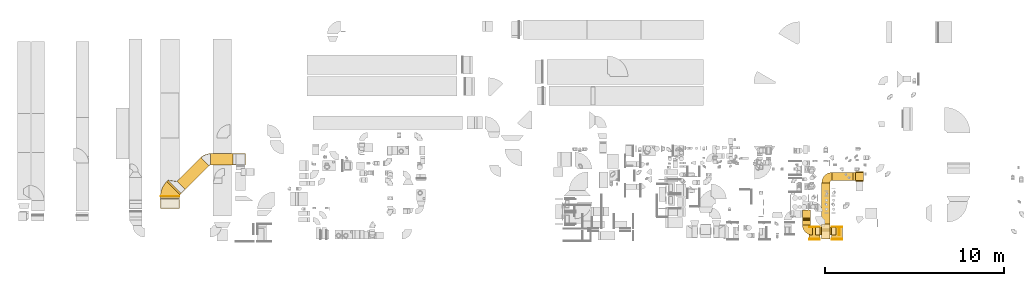
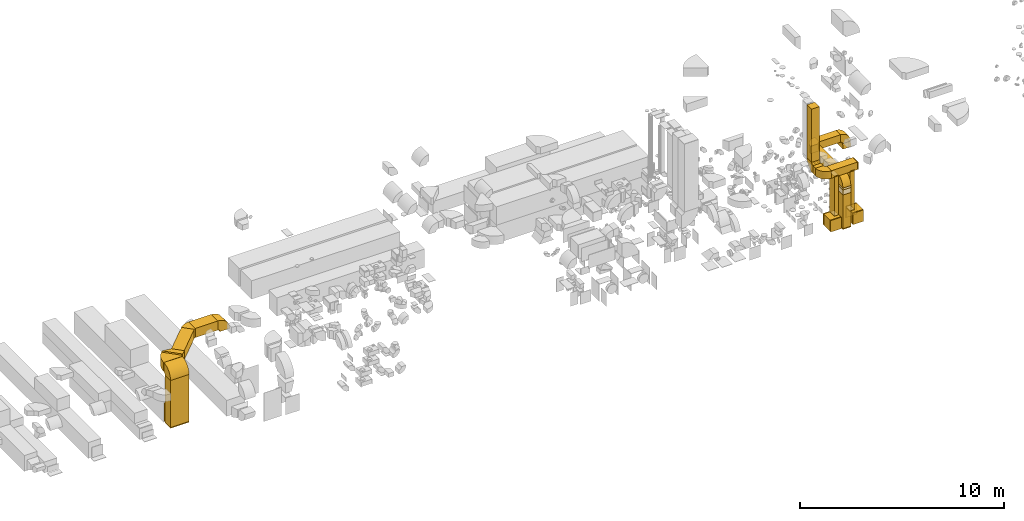
# One storey, part 1 of 59: 40 coverings.
"""IFC2X3 building model written with IfcOpenShell, lengths in millimetres."""

from ifc_helpers import new_model, entity, si_unit, converted_unit, derived_unit, direction, frame, frame_2d, origin, origin_2d_with_axis, place, context, subcontext, project, spatial, polyline, circle_curve, parameter, trimmed, segment, composite_curve, rectangle, outline, extrude, element, save


model = new_model("IFC2X3")

# Units and contexts
model_context = context("Model", 3, precision=0.01, world=origin(), true_north=direction((6.12303176911189e-17, 1.0)))
body_context = subcontext(model_context, "Body", "Model", "MODEL_VIEW")
ifc_project = project(units=[si_unit("LENGTHUNIT", "METRE", prefix="MILLI"), si_unit("AREAUNIT", "SQUARE_METRE"), si_unit("VOLUMEUNIT", "CUBIC_METRE"), converted_unit("PLANEANGLEUNIT", "DEGREE", entity("IfcRatioMeasure", 0.0174532925199433), si_unit("PLANEANGLEUNIT", "RADIAN"), dimensions=[0, 0, 0, 0, 0, 0, 0]), si_unit("MASSUNIT", "GRAM", prefix="KILO"), derived_unit("MASSDENSITYUNIT", [(si_unit("MASSUNIT", "GRAM", prefix="KILO"), 1), (si_unit("LENGTHUNIT", "METRE"), -3)]), derived_unit("MOMENTOFINERTIAUNIT", [(si_unit("LENGTHUNIT", "METRE"), 4)]), si_unit("TIMEUNIT", "SECOND"), si_unit("FREQUENCYUNIT", "HERTZ"), si_unit("THERMODYNAMICTEMPERATUREUNIT", "DEGREE_CELSIUS"), derived_unit("THERMALTRANSMITTANCEUNIT", [(si_unit("MASSUNIT", "GRAM", prefix="KILO"), 1), (si_unit("THERMODYNAMICTEMPERATUREUNIT", "KELVIN"), -1), (si_unit("TIMEUNIT", "SECOND"), -3)]), derived_unit("VOLUMETRICFLOWRATEUNIT", [(si_unit("LENGTHUNIT", "METRE"), 3), (si_unit("TIMEUNIT", "SECOND"), -1)]), derived_unit("MASSFLOWRATEUNIT", [(si_unit("MASSUNIT", "GRAM", prefix="KILO"), 1), (si_unit("TIMEUNIT", "SECOND"), -1)]), derived_unit("ROTATIONALFREQUENCYUNIT", [(si_unit("TIMEUNIT", "SECOND"), -1)]), si_unit("ELECTRICCURRENTUNIT", "AMPERE"), si_unit("ELECTRICVOLTAGEUNIT", "VOLT"), si_unit("POWERUNIT", "WATT"), si_unit("FORCEUNIT", "NEWTON", prefix="KILO"), si_unit("ILLUMINANCEUNIT", "LUX"), si_unit("LUMINOUSFLUXUNIT", "LUMEN"), si_unit("LUMINOUSINTENSITYUNIT", "CANDELA"), derived_unit("USERDEFINED", [(si_unit("MASSUNIT", "GRAM", prefix="KILO"), -1), (si_unit("LENGTHUNIT", "METRE"), -2), (si_unit("TIMEUNIT", "SECOND"), 3), (si_unit("LUMINOUSFLUXUNIT", "LUMEN"), 1)]), derived_unit("LINEARVELOCITYUNIT", [(si_unit("LENGTHUNIT", "METRE"), 1), (si_unit("TIMEUNIT", "SECOND"), -1)]), si_unit("PRESSUREUNIT", "PASCAL"), derived_unit("USERDEFINED", [(si_unit("LENGTHUNIT", "METRE"), -2), (si_unit("MASSUNIT", "GRAM", prefix="KILO"), 1), (si_unit("TIMEUNIT", "SECOND"), -2)]), derived_unit("LINEARFORCEUNIT", [(si_unit("MASSUNIT", "GRAM", prefix="KILO"), 1), (si_unit("LENGTHUNIT", "METRE"), 1), (si_unit("TIMEUNIT", "SECOND"), -2), (si_unit("LENGTHUNIT", "METRE"), -1)]), derived_unit("PLANARFORCEUNIT", [(si_unit("MASSUNIT", "GRAM", prefix="KILO"), 1), (si_unit("LENGTHUNIT", "METRE"), 1), (si_unit("TIMEUNIT", "SECOND"), -2), (si_unit("LENGTHUNIT", "METRE"), -2)])], contexts=[model_context])

# Site, building, storey
site_placement = place(None, origin())
site = spatial("IfcSite", under=ifc_project, at=site_placement, CompositionType="ELEMENT")
building_placement = place(site_placement, origin())
building = spatial("IfcBuilding", under=site, at=building_placement, CompositionType="ELEMENT")
storey_placement = place(building_placement, frame((0.0, 0.0, 28200.0)))
storey = spatial("IfcBuildingStorey", under=building, at=storey_placement, CompositionType="ELEMENT", Elevation=28200.0)

# Coverings
for number, where in (
    (1, (56172.0, 7958.29, 277.0)),
    (2, (57422.0, 7958.29, 277.0)),
):
    element("IfcCovering", number, at=place(storey_placement, frame(where)), inside=storey, PredefinedType="INSULATION", context=body_context, shape_type="SweptSolid", body=[
        extrude(rectangle(XDim=630.0, YDim=600.000000000002, at=origin_2d_with_axis()), frame((300.0, 315.0, 0.0), z_axis=(0.0, 0.0, 1.0), x_axis=(0.0, 1.0, 0.0)), (0.0, 0.0, 1.0), 680.000000000001),
    ])
for number, where in (
    (3, (56522.0, 8163.29, 952.0)),
    (4, (57422.0, 8163.29, 952.0)),
):
    element("IfcCovering", number, at=place(storey_placement, frame(where)), inside=storey, PredefinedType="INSULATION", context=body_context, shape_type="SweptSolid", body=[
        extrude(rectangle(XDim=449.999999999999, YDim=249.999999999995, at=origin_2d_with_axis()), frame((125.0, 225.0, 0.0), z_axis=(0.0, 0.0, 1.0), x_axis=(0.0, -1.0, 0.0)), (0.0, 0.0, 1.0), 2328.0),
    ])
covering_1_placement = place(storey_placement, frame((56172.0, 8588.29, 277.0)))
element("IfcCovering", 5, at=covering_1_placement, inside=storey, PredefinedType="INSULATION", context=body_context, shape_type="SweptSolid", body=[
    extrude(rectangle(XDim=50.0000000000016, YDim=600.000000000002, at=origin_2d_with_axis()), frame((300.0, 25.0, 0.0), z_axis=(0.0, 0.0, 1.0), x_axis=(0.0, -1.0, 0.0)), (0.0, 0.0, 1.0), 680.000000000001),
])
covering_2_placement = place(storey_placement, frame((57422.0, 7908.29, 277.0)))
element("IfcCovering", 6, at=covering_2_placement, inside=storey, PredefinedType="INSULATION", context=body_context, shape_type="SweptSolid", body=[
    extrude(rectangle(XDim=50.0000000000016, YDim=600.000000000002, at=origin_2d_with_axis()), frame((300.0, 25.0, 0.0), z_axis=(0.0, 0.0, 1.0), x_axis=(0.0, 1.0, 0.0)), (0.0, 0.0, 1.0), 680.000000000001),
])
covering_3_placement = place(storey_placement, frame((57422.0, 8588.29, 277.0)))
element("IfcCovering", 7, at=covering_3_placement, inside=storey, PredefinedType="INSULATION", context=body_context, shape_type="SweptSolid", body=[
    extrude(rectangle(XDim=50.0000000000016, YDim=600.000000000002, at=origin_2d_with_axis()), frame((300.0, 25.0, 0.0), z_axis=(0.0, 0.0, 1.0), x_axis=(0.0, -1.0, 0.0)), (0.0, 0.0, 1.0), 680.000000000001),
])
covering_4_placement = place(storey_placement, frame((56361.0, 8163.29, 3275.0)))
element("IfcCovering", 8, at=covering_4_placement, inside=storey, PredefinedType="INSULATION", context=body_context, shape_type="SweptSolid", body=[
    extrude(rectangle(XDim=1467.5, YDim=449.999999999999, at=origin_2d_with_axis()), frame((733.75, 225.0, 0.0), z_axis=(0.0, 0.0, 1.0), x_axis=(-1.0, 0.0, 0.0)), (0.0, 0.0, 1.0), 450.000000000002),
])
covering_5_placement = place(storey_placement, frame((55786.0, 8738.29, 3275.0)))
element("IfcCovering", 9, at=covering_5_placement, inside=storey, PredefinedType="INSULATION", context=body_context, shape_type="SweptSolid", body=[
    extrude(rectangle(XDim=244.711194999999, YDim=450.000000000002, at=origin_2d_with_axis()), frame((225.0, 122.36, 0.0), z_axis=(0.0, 0.0, 1.0), x_axis=(0.0, 1.0, 0.0)), (0.0, 0.0, 1.0), 450.000000000002),
])
covering_6_placement = place(storey_placement, frame((55786.0, 9108.0, 3850.0)))
element("IfcCovering", 10, at=covering_6_placement, inside=storey, PredefinedType="INSULATION", context=body_context, shape_type="SweptSolid", body=[
    extrude(rectangle(XDim=449.999999999999, YDim=450.000000000002, at=origin_2d_with_axis()), frame((225.0, 225.0, 0.0), z_axis=(0.0, 0.0, 1.0), x_axis=(0.0, 1.0, 0.0)), (0.0, 0.0, 1.0), 3175.169278549),
])
for number, where in (
    (11, (56522.0, 8163.29, 900.9)),
    (12, (56522.0, 8163.29, 3280.0)),
    (13, (57422.0, 8163.29, 900.9)),
    (14, (57422.0, 8163.29, 3280.0)),
):
    element("IfcCovering", number, at=place(storey_placement, frame(where)), inside=storey, PredefinedType="INSULATION", context=body_context, shape_type="SweptSolid", body=[
        extrude(rectangle(XDim=449.999999999999, YDim=250.000000000004, at=origin_2d_with_axis()), frame((125.0, 225.0, 0.0), z_axis=(0.0, 0.0, 1.0), x_axis=(0.0, -1.0, 0.0)), (0.0, 0.0, 1.0), 51.0960000000016),
    ])
covering_7_placement = place(storey_placement, frame((57828.5, 8163.29, 3275.0)))
element("IfcCovering", 15, at=covering_7_placement, inside=storey, PredefinedType="INSULATION", context=body_context, shape_type="SweptSolid", body=[
    extrude(rectangle(XDim=49.9999999999973, YDim=450.000000000001, at=origin_2d_with_axis()), frame((25.0, 225.0, 0.0), z_axis=(0.0, 0.0, 1.0), x_axis=(-1.0, 0.0, 0.0)), (0.0, 0.0, 1.0), 450.000000000002),
])
covering_8_placement = place(storey_placement, frame((56172.0, 7908.29, 277.0)))
element("IfcCovering", 16, at=covering_8_placement, inside=storey, PredefinedType="INSULATION", context=body_context, shape_type="SweptSolid", body=[
    extrude(rectangle(XDim=50.0000000000016, YDim=600.000000000002, at=origin_2d_with_axis()), frame((300.0, 25.0, 0.0), z_axis=(0.0, 0.0, 1.0), x_axis=(0.0, 1.0, 0.0)), (0.0, 0.0, 1.0), 680.000000000001),
])
covering_9_placement = place(storey_placement, frame((22661.4, 12073.31, 3175.0)))
element("IfcCovering", 17, at=covering_9_placement, inside=storey, PredefinedType="INSULATION", context=body_context, shape_type="SweptSolid", body=[
    extrude(rectangle(XDim=1267.90195093996, YDim=650.0, at=origin_2d_with_axis()), frame((633.95, 325.0, 0.0), z_axis=(0.0, 0.0, 1.0), x_axis=(-1.0, 0.0, 0.0)), (0.0, 0.0, 1.0), 549.999999999996),
])
covering_10_placement = place(storey_placement, frame((19864.38, 9661.65, 242.0)))
element("IfcCovering", 18, at=covering_10_placement, inside=storey, PredefinedType="INSULATION", context=body_context, shape_type="SweptSolid", body=[
    extrude(rectangle(XDim=550.000000000001, YDim=1050.0, at=origin_2d_with_axis()), frame((525.0, 275.0, 0.0), z_axis=(0.0, 0.0, 1.0), x_axis=(0.0, -1.0, 0.0)), (0.0, 0.0, 1.0), 2808.00000000001),
])
covering_11_placement = place(storey_placement, frame((19864.38, 10326.3, 3175.0)))
element("IfcCovering", 19, at=covering_11_placement, inside=storey, PredefinedType="INSULATION", context=body_context, shape_type="SweptSolid", body=[
    extrude(rectangle(XDim=10.3524324444996, YDim=1050.0, at=origin_2d_with_axis()), frame((525.0, 5.18, 0.0), z_axis=(0.0, -1.35659843300878e-07, 1.0), x_axis=(0.0, -1.0, -1.35659843300878e-07)), (0.0, 0.0, 1.0), 550.000000000001),
])
covering_12_placement = place(storey_placement, frame((20208.53, 10414.68, 3175.0)))
element("IfcCovering", 20, at=covering_12_placement, inside=storey, PredefinedType="INSULATION", context=body_context, shape_type="SweptSolid", body=[
    extrude(rectangle(XDim=110.761184457499, YDim=1050.0, at=origin_2d_with_axis()), frame((410.39, 410.39, 0.0), z_axis=(-7.55457589572577e-09, -7.55457589572588e-09, 1.0), x_axis=(0.707106781186538, 0.707106781186557, 1.06837836897123e-08)), (0.0, 0.0, 1.0), 549.999999999996),
])
covering_13_placement = place(storey_placement, frame((20781.82, 10705.14, 3175.0)))
element("IfcCovering", 21, at=covering_13_placement, inside=storey, PredefinedType="INSULATION", context=body_context, shape_type="SweptSolid", body=[
    extrude(rectangle(XDim=1883.11718226002, YDim=649.999999999997, at=origin_2d_with_axis()), frame((895.59, 895.59, 0.0), z_axis=(-1.10951751218412e-09, -1.10951751218413e-09, 1.0), x_axis=(0.707106781186549, 0.707106781186546, 1.56909471342124e-09)), (0.0, 0.0, 1.0), 549.999999999996),
])
covering_14_placement = place(storey_placement, frame((20286.85, 10493.0, 3175.0)))
element("IfcCovering", 22, at=covering_14_placement, inside=storey, PredefinedType="INSULATION", context=body_context, shape_type="SweptSolid", body=[
    extrude(outline(polyline([(-150.0, -425.0), (150.0, -425.0), (150.0, 225.0), (-150.0, 625.0), (-150.0, -425.0)])), frame((548.01, 406.59, 0.0), z_axis=(-4.57021901919309e-08, -4.57021901919276e-08, 1.0), x_axis=(0.707106781186727, 0.707106781186366, 6.4632657199581e-08)), (0.0, 0.0, 1.0), 549.999999999997),
])
covering_15_placement = place(storey_placement, frame((19864.38, 9661.65, 192.0)))
element("IfcCovering", 23, at=covering_15_placement, inside=storey, PredefinedType="INSULATION", context=body_context, shape_type="SweptSolid", body=[
    extrude(rectangle(XDim=550.0, YDim=1050.0, at=origin_2d_with_axis()), frame((525.0, 275.0, 0.0), z_axis=(0.0, 0.0, 1.0), x_axis=(0.0, 1.0, 0.0)), (0.0, 0.0, 1.0), 50.0000000000016),
])
covering_16_placement = place(storey_placement, frame((19864.38, 10206.65, 257.0)))
element("IfcCovering", 24, at=covering_16_placement, inside=storey, PredefinedType="INSULATION", context=body_context, shape_type="SweptSolid", body=[
    extrude(rectangle(XDim=119.999999999994, YDim=1050.0, at=origin_2d_with_axis()), frame((525.0, 60.0, 0.0), z_axis=(0.0, 0.0, 1.0), x_axis=(0.0, -1.0, 0.0)), (0.0, 0.0, 1.0), 1050.0),
])
covering_17_placement = place(storey_placement, frame((57447.0, 11214.32, 2775.0)))
element("IfcCovering", 25, at=covering_17_placement, inside=storey, PredefinedType="INSULATION", context=body_context, shape_type="SweptSolid", body=[
    extrude(rectangle(XDim=1182.90417000001, YDim=450.000000000002, at=origin_2d_with_axis()), frame((591.45, 225.0, 0.0), z_axis=(0.0, 0.0, 1.0), x_axis=(-1.0, 0.0, 0.0)), (0.0, 0.0, 1.0), 450.000000000002),
])
covering_18_placement = place(storey_placement, frame((56872.0, 8504.29, 2775.0)))
element("IfcCovering", 26, at=covering_18_placement, inside=storey, PredefinedType="INSULATION", context=body_context, shape_type="SweptSolid", body=[
    extrude(rectangle(XDim=2585.02945260871, YDim=450.000000000002, at=origin_2d_with_axis()), frame((225.0, 1292.51, 0.0), z_axis=(0.0, -1.90059958557437e-08, 1.0), x_axis=(0.0, -1.0, -1.90059958557437e-08)), (0.0, 0.0, 1.0), 450.000000000002),
])
covering_19_placement = place(storey_placement, frame((56872.0, 7929.29, 2532.17)))
element("IfcCovering", 27, at=covering_19_placement, inside=storey, PredefinedType="INSULATION", context=body_context, shape_type="SweptSolid", body=[
    extrude(rectangle(XDim=450.000000000002, YDim=449.999999999999, at=origin_2d_with_axis()), frame((225.0, 225.0, 0.0), z_axis=(0.0, 0.0, 1.0), x_axis=(-1.0, 0.0, 0.0)), (0.0, 0.0, 1.0), 117.830633338828),
])
covering_20_placement = place(storey_placement, frame((56872.0, 7929.21, 217.57)))
element("IfcCovering", 28, at=covering_20_placement, inside=storey, PredefinedType="INSULATION", context=body_context, shape_type="SweptSolid", body=[
    extrude(rectangle(XDim=850.0, YDim=450.000000000002, at=origin_2d_with_axis()), frame((225.0, 425.0, 0.0), z_axis=(0.0, 0.0, 1.0), x_axis=(0.0, 1.0, 0.0)), (0.0, 0.0, 1.0), 2014.6001016),
])
covering_21_placement = place(storey_placement, frame((56872.0, 7929.21, 2232.17)))
element("IfcCovering", 29, at=covering_21_placement, inside=storey, PredefinedType="INSULATION", context=body_context, shape_type="SweptSolid", body=[
    extrude(outline(polyline([(-149.91, -325.0), (150.09, -325.0), (149.86, 525.0), (-150.03, 125.0), (-149.91, -325.0)])), frame((0.0, 325.04, 150.0), z_axis=(1.0, 0.0, 0.0), x_axis=(0.0, -0.000269427198978266, -0.999999963704492)), (0.0, 0.0, 1.0), 449.999999999993),
])
covering_22_placement = place(storey_placement, frame((56872.0, 7929.21, 167.57)))
element("IfcCovering", 30, at=covering_22_placement, inside=storey, PredefinedType="INSULATION", context=body_context, shape_type="SweptSolid", body=[
    extrude(rectangle(XDim=450.000000000002, YDim=850.000000000001, at=origin_2d_with_axis()), frame((225.0, 425.0, 0.0)), (0.0, 0.0, 1.0), 50.0000000000016),
])
covering_23_placement = place(storey_placement, frame((58754.9, 11164.32, 2350.0)))
element("IfcCovering", 31, at=covering_23_placement, inside=storey, PredefinedType="INSULATION", context=body_context, shape_type="SweptSolid", body=[
    extrude(outline(polyline([(-110.97, -246.6), (193.17, -246.6), (102.75, 295.92), (-184.95, 197.28), (-110.97, -246.6)])), frame((0.0, 275.0, 150.0), z_axis=(1.0, 0.0, 0.0), x_axis=(0.0, -0.164398987305147, -0.986393923832179)), (0.0, 0.0, 1.0), 450.000000000002),
])
covering_24_placement = place(storey_placement, frame((55784.4, 8161.69, 3275.0)))
element("IfcCovering", 32, at=covering_24_placement, inside=storey, PredefinedType="INSULATION", context=body_context, shape_type="SweptSolid", body=[
    extrude(outline(composite_curve([segment(polyline([(-175.0, 50.0), (-175.0, -400.0)]), True, "CONTINUOUS"), segment(trimmed(circle_curve(frame_2d((-175.0, 175.0), x_axis=(1.0, 0.0)), 575.0), [parameter(270.0)], [parameter(0.0)], True, "PARAMETER"), True, "CONTINUOUS"), segment(polyline([(400.0, 175.0), (-50.0, 175.0)]), True, "CONTINUOUS"), segment(trimmed(circle_curve(frame_2d((-175.0, 175.0), x_axis=(1.0, 0.0)), 125.0), [parameter(270.0)], [parameter(360.0)], True, "PARAMETER"), False, "CONTINUOUS")], self_intersect=False)), frame((401.6, 401.6, 0.0), z_axis=(0.0, 0.0, -1.0), x_axis=(-1.0, 0.0, 0.0)), (0.0, 0.0, -1.0), 450.000000000002),
])
covering_25_placement = place(storey_placement, frame((55786.0, 8981.4, 3273.4)))
element("IfcCovering", 33, at=covering_25_placement, inside=storey, PredefinedType="INSULATION", context=body_context, shape_type="SweptSolid", body=[
    extrude(outline(composite_curve([segment(polyline([(-175.0, 50.0), (-175.0, -400.0)]), True, "CONTINUOUS"), segment(trimmed(circle_curve(frame_2d((-175.0, 175.0), x_axis=(1.0, 0.0)), 575.0), [parameter(270.0)], [parameter(0.0)], True, "PARAMETER"), True, "CONTINUOUS"), segment(polyline([(400.0, 175.0), (-50.0, 175.0)]), True, "CONTINUOUS"), segment(trimmed(circle_curve(frame_2d((-175.0, 175.0), x_axis=(1.0, 0.0)), 125.0), [parameter(270.0)], [parameter(360.0)], True, "PARAMETER"), False, "CONTINUOUS")], self_intersect=False)), frame((0.0, 176.6, 401.6), z_axis=(-1.0, 0.0, 0.0), x_axis=(0.0, 0.0, -1.0)), (0.0, 0.0, -1.0), 450.000000000002),
])
covering_26_placement = place(storey_placement, frame((23927.7, 12073.31, 3048.4)))
element("IfcCovering", 34, at=covering_26_placement, inside=storey, PredefinedType="INSULATION", context=body_context, shape_type="SweptSolid", body=[
    extrude(outline(composite_curve([segment(polyline([(-200.0, 75.0), (-200.0, -475.0)]), True, "CONTINUOUS"), segment(trimmed(circle_curve(frame_2d((-200.0, 200.0), x_axis=(1.0, 0.0)), 675.0), [parameter(270.0)], [parameter(0.0)], True, "PARAMETER"), True, "CONTINUOUS"), segment(polyline([(475.0, 200.0), (-75.0, 200.0)]), True, "CONTINUOUS"), segment(trimmed(circle_curve(frame_2d((-200.0, 200.0), x_axis=(1.0, 0.0)), 125.0), [parameter(270.0)], [parameter(360.0)], True, "PARAMETER"), False, "CONTINUOUS")], self_intersect=False)), frame((201.6, 0.0, 201.6), z_axis=(0.0, -1.0, 0.0), x_axis=(0.0, 0.0, 1.0)), (0.0, 0.0, -1.0), 650.0),
])
covering_27_placement = place(storey_placement, frame((19864.38, 9660.05, 3048.4)))
element("IfcCovering", 35, at=covering_27_placement, inside=storey, PredefinedType="INSULATION", context=body_context, shape_type="SweptSolid", body=[
    extrude(outline(composite_curve([segment(polyline([(-75.0, -200.0), (475.0, -200.0)]), True, "CONTINUOUS"), segment(trimmed(circle_curve(frame_2d((-200.0, -200.0), x_axis=(0.0, 1.0)), 675.0), [parameter(270.0)], [parameter(0.0)], True, "PARAMETER"), True, "CONTINUOUS"), segment(polyline([(-200.0, 475.0), (-200.0, -75.0)]), True, "CONTINUOUS"), segment(trimmed(circle_curve(frame_2d((-200.0, -200.0), x_axis=(0.0, 1.0)), 125.0), [parameter(270.0)], [parameter(360.0)], True, "PARAMETER"), False, "CONTINUOUS")], self_intersect=False)), frame((0.0, 476.6, 201.6), z_axis=(1.0, 0.0, 0.0), x_axis=(0.0, 0.0, 1.0)), (0.0, 0.0, 1.0), 1050.0),
])
covering_28_placement = place(storey_placement, frame((19862.78, 10324.7, 3175.0)))
element("IfcCovering", 36, at=covering_28_placement, inside=storey, PredefinedType="INSULATION", context=body_context, shape_type="SweptSolid", body=[
    extrude(outline(composite_curve([segment(polyline([(-466.42, 141.42), (276.04, -601.04)]), True, "CONTINUOUS"), segment(trimmed(circle_curve(frame_2d((-554.81, 229.81), x_axis=(1.0, 0.0)), 1175.0), [parameter(315.0)], [parameter(0.0)], True, "PARAMETER"), True, "CONTINUOUS"), segment(polyline([(620.19, 229.81), (-429.81, 229.81)]), True, "CONTINUOUS"), segment(trimmed(circle_curve(frame_2d((-554.81, 229.81), x_axis=(1.0, 0.0)), 125.0), [parameter(315.0)], [parameter(360.0)], True, "PARAMETER"), False, "CONTINUOUS")], self_intersect=False)), frame((621.79, 231.4, 0.0), z_axis=(1.51091211771006e-08, 0.0, -1.0), x_axis=(-0.707106781186567, 0.707106781186528, -1.06837620420974e-08)), (0.0, 0.0, -1.0), 549.999999999996),
])
covering_29_placement = place(storey_placement, frame((22111.79, 12035.11, 3175.0)))
element("IfcCovering", 37, at=covering_29_placement, inside=storey, PredefinedType="INSULATION", context=body_context, shape_type="SweptSolid", body=[
    extrude(outline(composite_curve([segment(polyline([(-295.71, 70.71), (163.91, -388.91)]), True, "CONTINUOUS"), segment(trimmed(circle_curve(frame_2d((-384.1, 159.1), x_axis=(1.0, 0.0)), 775.0), [parameter(315.0)], [parameter(0.0)], True, "PARAMETER"), True, "CONTINUOUS"), segment(polyline([(390.9, 159.1), (-259.1, 159.1)]), True, "CONTINUOUS"), segment(trimmed(circle_curve(frame_2d((-384.1, 159.1), x_axis=(1.0, 0.0)), 125.0), [parameter(315.0)], [parameter(360.0)], True, "PARAMETER"), False, "CONTINUOUS")], self_intersect=False)), frame((390.5, 297.31, 0.0), z_axis=(0.0, 0.0, -1.0), x_axis=(0.0, 1.0, 0.0)), (0.0, 0.0, -1.0), 549.999999999996),
])
covering_30_placement = place(storey_placement, frame((58628.31, 11214.32, 2648.4)))
element("IfcCovering", 38, at=covering_30_placement, inside=storey, PredefinedType="INSULATION", context=body_context, shape_type="SweptSolid", body=[
    extrude(outline(composite_curve([segment(polyline([(-50.0, -175.0), (400.0, -175.0)]), True, "CONTINUOUS"), segment(trimmed(circle_curve(frame_2d((-175.0, -175.0), x_axis=(0.0, 1.0)), 575.0), [parameter(270.0)], [parameter(0.0)], True, "PARAMETER"), True, "CONTINUOUS"), segment(polyline([(-175.0, 400.0), (-175.0, -50.0)]), True, "CONTINUOUS"), segment(trimmed(circle_curve(frame_2d((-175.0, -175.0), x_axis=(0.0, 1.0)), 125.0), [parameter(270.0)], [parameter(360.0)], True, "PARAMETER"), False, "CONTINUOUS")], self_intersect=False)), frame((176.6, 0.0, 176.6), z_axis=(0.0, 1.0, 0.0), x_axis=(0.0, 0.0, 1.0)), (0.0, 0.0, 1.0), 450.000000000002),
])
covering_31_placement = place(storey_placement, frame((56870.4, 11087.72, 2775.0)))
element("IfcCovering", 39, at=covering_31_placement, inside=storey, PredefinedType="INSULATION", context=body_context, shape_type="SweptSolid", body=[
    extrude(outline(composite_curve([segment(polyline([(-175.0, 50.0), (-175.0, -400.0)]), True, "CONTINUOUS"), segment(trimmed(circle_curve(frame_2d((-175.0, 175.0), x_axis=(1.0, 0.0)), 575.0), [parameter(270.0)], [parameter(0.0)], True, "PARAMETER"), True, "CONTINUOUS"), segment(polyline([(400.0, 175.0), (-50.0, 175.0)]), True, "CONTINUOUS"), segment(trimmed(circle_curve(frame_2d((-175.0, 175.0), x_axis=(1.0, 0.0)), 125.0), [parameter(270.0)], [parameter(360.0)], True, "PARAMETER"), False, "CONTINUOUS")], self_intersect=False)), frame((401.6, 176.6, 0.0), z_axis=(0.0, 0.0, -1.0), x_axis=(0.0, 1.0, 0.0)), (0.0, 0.0, -1.0), 450.000000000002),
])
covering_32_placement = place(storey_placement, frame((56872.0, 7927.69, 2648.4)))
element("IfcCovering", 40, at=covering_32_placement, inside=storey, PredefinedType="INSULATION", context=body_context, shape_type="SweptSolid", body=[
    extrude(outline(composite_curve([segment(polyline([(-175.0, 50.0), (-175.0, -400.0)]), True, "CONTINUOUS"), segment(trimmed(circle_curve(frame_2d((-175.0, 175.0), x_axis=(1.0, 0.0)), 575.0), [parameter(270.000001088963)], [parameter(0.0)], True, "PARAMETER"), True, "CONTINUOUS"), segment(polyline([(400.0, 175.0), (-50.0, 175.0)]), True, "CONTINUOUS"), segment(trimmed(circle_curve(frame_2d((-175.0, 175.0), x_axis=(1.0, 0.0)), 125.0), [parameter(270.000001088963)], [parameter(360.0)], True, "PARAMETER"), False, "CONTINUOUS")], self_intersect=False)), frame((0.0, 401.6, 176.6), z_axis=(-1.0, 0.0, 0.0), x_axis=(0.0, -1.90059961390206e-08, 1.0)), (0.0, 0.0, -1.0), 450.000000000001),
])

save(model, "model.ifc")
